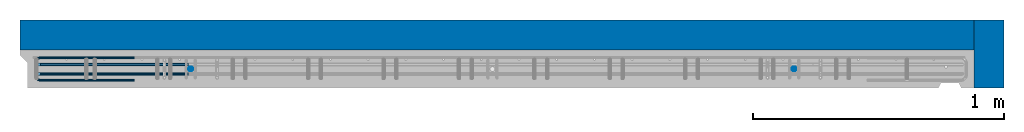
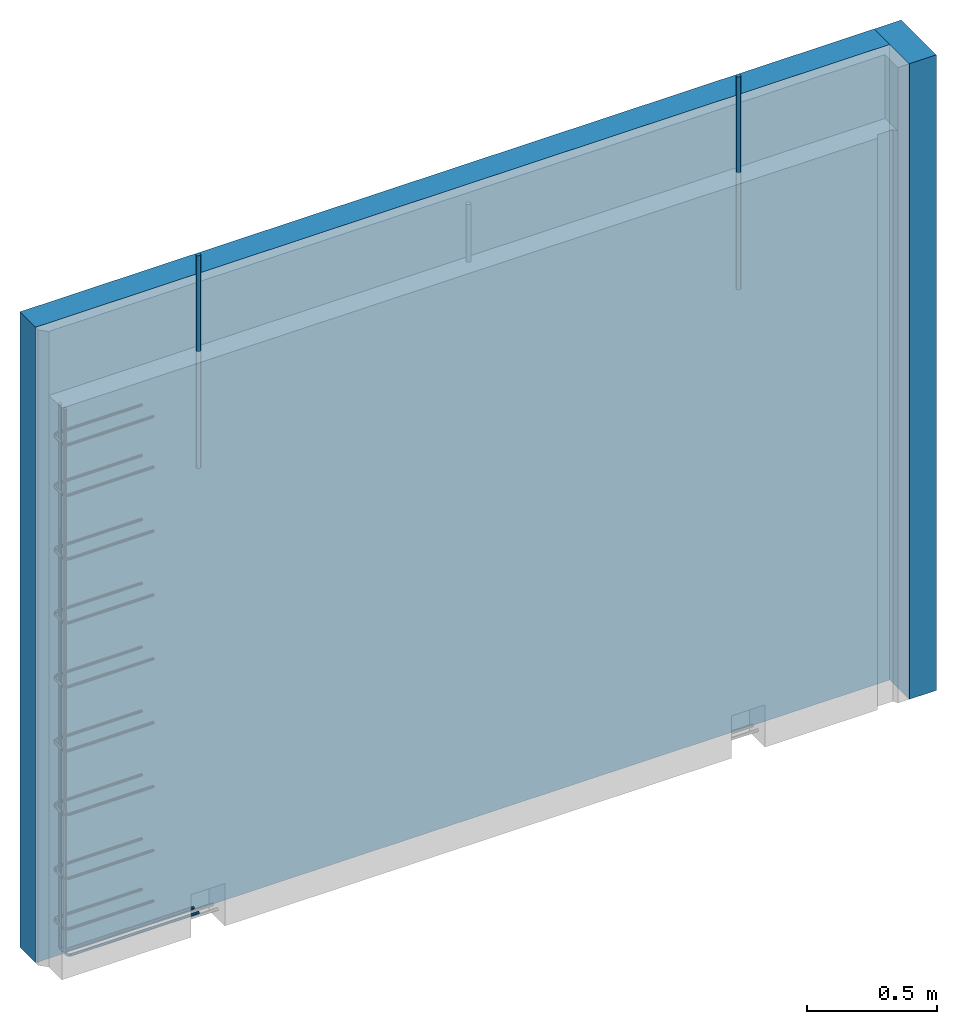
# One storey, part 1 of 9: 3 reinforcing bars, 2 walls, 1 element without a shape of its own.
"""IFC2X3 building model written with IfcOpenShell, lengths in millimetres."""

from ifc_helpers import new_model, entity, si_unit, frame, origin_with_axes, place, context, subcontext, project, spatial, faceted_brep, source, transform, mapped, material, type_object, element, aggregate, save


model = new_model("IFC2X3")

# Units and contexts
model_context = context("Model", 3, precision=1e-05, world=origin_with_axes())
body_context = subcontext(model_context, "Body", "Model", "MODEL_VIEW")
ifc_project = project(units=[si_unit("LENGTHUNIT", "METRE", prefix="MILLI"), si_unit("AREAUNIT", "SQUARE_METRE"), si_unit("VOLUMEUNIT", "CUBIC_METRE"), si_unit("MASSUNIT", "GRAM", prefix="KILO"), si_unit("TIMEUNIT", "SECOND"), si_unit("PLANEANGLEUNIT", "RADIAN"), si_unit("SOLIDANGLEUNIT", "STERADIAN"), si_unit("THERMODYNAMICTEMPERATUREUNIT", "DEGREE_CELSIUS"), si_unit("LUMINOUSINTENSITYUNIT", "LUMEN")], contexts=[model_context])

# Site, building, storey
site_placement = place(None, origin_with_axes())
site = spatial("IfcSite", under=ifc_project, at=site_placement, CompositionType="ELEMENT")
building_placement = place(site_placement, origin_with_axes())
building = spatial("IfcBuilding", under=site, at=building_placement, Name="1", CompositionType="ELEMENT")
storey_placement = place(building_placement, origin_with_axes())
storey = spatial("IfcBuildingStorey", under=building, at=storey_placement, Name="1. kerros", CompositionType="ELEMENT", Elevation=0.0)

# Assembly, walls, reinforcing bars
assembly_placement = place(storey_placement, origin_with_axes())
assembly = element("IfcElementAssembly", 1, at=assembly_placement, inside=storey, AssemblyPlace="NOTDEFINED", PredefinedType="REINFORCEMENT_UNIT")
ifc_material_1 = material(Name="K15")
wall_type = type_object("IfcWallType", Name="2985X120", PredefinedType="NOTDEFINED")
wall_1_placement = place(assembly_placement, frame((41470.0064188799, 6710.00033181262, 1492.49992145828), z_axis=(0.0, 0.0, 1.0), x_axis=(0.999999999502078, -3.15569999841783e-05, 0.0)))
wall_1 = element("IfcWall", 2, at=wall_1_placement, type_object=wall_type, material=ifc_material_1, Name="KINGSPAN", ObjectType="2985X120", context=body_context, shape_type="Brep", body=[
    faceted_brep([(-7.27595761418343e-12, 60.0, -1492.5), (-7.27595761418343e-12, 60.0, 1492.5), (3794.40130344179, 60.0, 1492.5), (3794.40130344179, 60.0, -1492.5), (-7.27595761418343e-12, -60.0000000000009, 1492.5), (3794.40130344179, -60.0, 1492.5), (-7.27595761418343e-12, -60.0000000000009, -1492.5), (3794.40130344179, -60.0, -1492.5)], [[[0, 1, 2, 3]], [[1, 4, 5, 2]], [[4, 6, 7, 5]], [[6, 0, 3, 7]], [[5, 7, 3, 2]], [[6, 4, 1, 0]]]),
])
wall_2_placement = place(assembly_placement, frame((45324.4033074056, 6499.89551753884, 1492.49992151563), z_axis=(0.0, 0.0, 1.0), x_axis=(0.0, 1.0, 0.0)))
wall_2 = element("IfcWall", 3, at=wall_2_placement, type_object=wall_type, material=ifc_material_1, Name="KINGSPAN", ObjectType="2985X120", context=body_context, shape_type="Brep", body=[
    faceted_brep([(-7.27595761418343e-12, 60.0, -1492.5), (-7.27595761418343e-12, 60.0, 1492.5), (269.985074299451, 60.0, 1492.5), (269.985074299451, 60.0, -1492.5), (-7.27595761418343e-12, -60.0000000000009, 1492.5), (269.985074299451, -60.0, 1492.5), (-7.27595761418343e-12, -60.0000000000009, -1492.5), (269.985074299451, -60.0, -1492.5)], [[[0, 1, 2, 3]], [[1, 4, 5, 2]], [[4, 6, 7, 5]], [[6, 0, 3, 7]], [[5, 7, 3, 2]], [[6, 4, 1, 0]]]),
])
ifc_material_2 = material(Name="B500B")
shared_shape_1 = source(origin_with_axes(), body_context, "Body", "AdvancedSweptSolid", [
    entity("IfcSweptDiskSolid", entity("IfcTrimmedCurve", entity("IfcLine", entity("IfcCartesianPoint", [0.0, 0.0, 0.0]), entity("IfcVector", entity("IfcDirection", [1.0, 0.0, 0.0]), 1.0)), [entity("IfcParameterValue", 0.0)], [entity("IfcParameterValue", 1000.0)], True, "PARAMETER"), 9.5, None, 0.0, 1000.0),
])
shared_shape_2 = source(origin_with_axes(), body_context, "Body", "AdvancedSweptSolid", [
    entity("IfcSweptDiskSolid", entity("IfcTrimmedCurve", entity("IfcLine", entity("IfcCartesianPoint", [0.0, 0.0, 0.0]), entity("IfcVector", entity("IfcDirection", [1.0, 0.0, 0.0]), 1.0)), [entity("IfcParameterValue", 0.0)], [entity("IfcParameterValue", 1000.0)], True, "PARAMETER"), 9.5, None, 0.0, 1000.0),
])
reinforcing_bar_1_placement = place(assembly_placement, frame((41470.0027153252, 6590.00033186975, 2539.99992157502), z_axis=(-0.000154210000015155, -0.999999988109638, 0.0), x_axis=(-1.34689347184514e-12, 3.00310696000483e-13, -1.0)))
reinforcing_bar_1 = element("IfcReinforcingBar", 4, at=reinforcing_bar_1_placement, material=ifc_material_2, BarRole="NOTDEFINED", CrossSectionArea=0.0, NominalDiameter=19.0, context=body_context, shape_type="MappedRepresentation", body=[
    mapped(shared_shape_1, transform((-595.0, 679.501855406641, 14.915869183149))),
    mapped(shared_shape_2, transform((-595.0, 3079.50183701462, 14.6187188032445))),
])
ifc_direction_1 = entity("IfcDirection", [0.0, -1.0, 0.0])
shared_shape_3 = source(origin_with_axes(), body_context, "Body", "AdvancedSweptSolid", [
    entity("IfcSweptDiskSolid", entity("IfcCompositeCurve", [entity("IfcCompositeCurveSegment", "CONTINUOUS", True, entity("IfcTrimmedCurve", entity("IfcLine", entity("IfcCartesianPoint", [0.0, 0.0, 0.0]), entity("IfcVector", entity("IfcDirection", [-0.999999999996908, 0.0, 2.4868612773608e-06]), 1.0)), [entity("IfcParameterValue", 0.0)], [entity("IfcParameterValue", 371.999930366745)], True, "PARAMETER")), entity("IfcCompositeCurveSegment", "CONTINUOUS", True, entity("IfcTrimmedCurve", entity("IfcCircle", entity("IfcAxis2Placement3D", entity("IfcCartesianPoint", [-371.999987563404, 0.0, -22.9990748877069]), ifc_direction_1, entity("IfcDirection", [2.48686127751752e-06, 0.0, 0.999999999996908])), 23.0), [entity("IfcParameterValue", 0.0)], [entity("IfcParameterValue", 1.57079881365545)], True, "PARAMETER")), entity("IfcCompositeCurveSegment", "CONTINUOUS", True, entity("IfcTrimmedCurve", entity("IfcLine", entity("IfcCartesianPoint", [-394.999987563404, 0.0, -22.9990748876901]), entity("IfcVector", entity("IfcDirection", [-1.34689347184514e-12, 3.00310696000483e-13, -1.0]), 1.0)), [entity("IfcParameterValue", 0.0)], [entity("IfcParameterValue", 44.0000413663064)], True, "PARAMETER")), entity("IfcCompositeCurveSegment", "CONTINUOUS", True, entity("IfcTrimmedCurve", entity("IfcCircle", entity("IfcAxis2Placement3D", entity("IfcCartesianPoint", [-371.999987563436, 0.0, -66.9991162540133]), ifc_direction_1, entity("IfcDirection", [-1.0, 0.0, 0.0])), 23.0), [entity("IfcParameterValue", 0.0)], [entity("IfcParameterValue", 1.57079383993429)], True, "PARAMETER")), entity("IfcCompositeCurveSegment", "DISCONTINUOUS", True, entity("IfcTrimmedCurve", entity("IfcLine", entity("IfcCartesianPoint", [-372.000044761247, 0.0, -89.9991162539422]), entity("IfcVector", entity("IfcDirection", [0.999999999996908, 0.0, -2.48686133034195e-06]), 1.0)), [entity("IfcParameterValue", 0.0)], [entity("IfcParameterValue", 372.000069630907)], True, "PARAMETER"))], False), 5.0, None, 0.0, 791.141634017549),
])
ifc_direction_2 = entity("IfcDirection", [0.0, -1.0, 0.0])
shared_shape_4 = source(origin_with_axes(), body_context, "Body", "AdvancedSweptSolid", [
    entity("IfcSweptDiskSolid", entity("IfcCompositeCurve", [entity("IfcCompositeCurveSegment", "CONTINUOUS", True, entity("IfcTrimmedCurve", entity("IfcLine", entity("IfcCartesianPoint", [0.0, 0.0, 0.0]), entity("IfcVector", entity("IfcDirection", [-0.999999999996908, 0.0, 2.4868612773608e-06]), 1.0)), [entity("IfcParameterValue", 0.0)], [entity("IfcParameterValue", 371.999930366745)], True, "PARAMETER")), entity("IfcCompositeCurveSegment", "CONTINUOUS", True, entity("IfcTrimmedCurve", entity("IfcCircle", entity("IfcAxis2Placement3D", entity("IfcCartesianPoint", [-371.999987563404, 0.0, -22.9990748877069]), ifc_direction_2, entity("IfcDirection", [2.48686127751752e-06, 0.0, 0.999999999996908])), 23.0), [entity("IfcParameterValue", 0.0)], [entity("IfcParameterValue", 1.57079881365545)], True, "PARAMETER")), entity("IfcCompositeCurveSegment", "CONTINUOUS", True, entity("IfcTrimmedCurve", entity("IfcLine", entity("IfcCartesianPoint", [-394.999987563404, 0.0, -22.9990748876901]), entity("IfcVector", entity("IfcDirection", [-1.34689347184514e-12, 3.00310696000483e-13, -1.0]), 1.0)), [entity("IfcParameterValue", 0.0)], [entity("IfcParameterValue", 44.0000413663064)], True, "PARAMETER")), entity("IfcCompositeCurveSegment", "CONTINUOUS", True, entity("IfcTrimmedCurve", entity("IfcCircle", entity("IfcAxis2Placement3D", entity("IfcCartesianPoint", [-371.999987563436, 0.0, -66.9991162540133]), ifc_direction_2, entity("IfcDirection", [-1.0, 0.0, 0.0])), 23.0), [entity("IfcParameterValue", 0.0)], [entity("IfcParameterValue", 1.57079383993429)], True, "PARAMETER")), entity("IfcCompositeCurveSegment", "DISCONTINUOUS", True, entity("IfcTrimmedCurve", entity("IfcLine", entity("IfcCartesianPoint", [-372.000044761247, 0.0, -89.9991162539422]), entity("IfcVector", entity("IfcDirection", [0.999999999996908, 0.0, -2.48686133034195e-06]), 1.0)), [entity("IfcParameterValue", 0.0)], [entity("IfcParameterValue", 372.000069630907)], True, "PARAMETER"))], False), 5.0, None, 0.0, 791.141634017549),
])
ifc_direction_3 = entity("IfcDirection", [0.0, -1.0, 0.0])
shared_shape_5 = source(origin_with_axes(), body_context, "Body", "AdvancedSweptSolid", [
    entity("IfcSweptDiskSolid", entity("IfcCompositeCurve", [entity("IfcCompositeCurveSegment", "CONTINUOUS", True, entity("IfcTrimmedCurve", entity("IfcLine", entity("IfcCartesianPoint", [0.0, 0.0, 0.0]), entity("IfcVector", entity("IfcDirection", [-0.999999999996908, 0.0, 2.4868612773608e-06]), 1.0)), [entity("IfcParameterValue", 0.0)], [entity("IfcParameterValue", 371.999930366745)], True, "PARAMETER")), entity("IfcCompositeCurveSegment", "CONTINUOUS", True, entity("IfcTrimmedCurve", entity("IfcCircle", entity("IfcAxis2Placement3D", entity("IfcCartesianPoint", [-371.999987563404, 0.0, -22.9990748877069]), ifc_direction_3, entity("IfcDirection", [2.48686127751752e-06, 0.0, 0.999999999996908])), 23.0), [entity("IfcParameterValue", 0.0)], [entity("IfcParameterValue", 1.57079881365545)], True, "PARAMETER")), entity("IfcCompositeCurveSegment", "CONTINUOUS", True, entity("IfcTrimmedCurve", entity("IfcLine", entity("IfcCartesianPoint", [-394.999987563404, 0.0, -22.9990748876901]), entity("IfcVector", entity("IfcDirection", [-1.34689347184514e-12, 3.00310696000483e-13, -1.0]), 1.0)), [entity("IfcParameterValue", 0.0)], [entity("IfcParameterValue", 44.0000413663064)], True, "PARAMETER")), entity("IfcCompositeCurveSegment", "CONTINUOUS", True, entity("IfcTrimmedCurve", entity("IfcCircle", entity("IfcAxis2Placement3D", entity("IfcCartesianPoint", [-371.999987563436, 0.0, -66.9991162540133]), ifc_direction_3, entity("IfcDirection", [-1.0, 0.0, 0.0])), 23.0), [entity("IfcParameterValue", 0.0)], [entity("IfcParameterValue", 1.57079383993429)], True, "PARAMETER")), entity("IfcCompositeCurveSegment", "DISCONTINUOUS", True, entity("IfcTrimmedCurve", entity("IfcLine", entity("IfcCartesianPoint", [-372.000044761247, 0.0, -89.9991162539422]), entity("IfcVector", entity("IfcDirection", [0.999999999996908, 0.0, -2.48686133034195e-06]), 1.0)), [entity("IfcParameterValue", 0.0)], [entity("IfcParameterValue", 372.000069630907)], True, "PARAMETER"))], False), 5.0, None, 0.0, 791.141634017549),
])
ifc_direction_4 = entity("IfcDirection", [0.0, -1.0, 0.0])
shared_shape_6 = source(origin_with_axes(), body_context, "Body", "AdvancedSweptSolid", [
    entity("IfcSweptDiskSolid", entity("IfcCompositeCurve", [entity("IfcCompositeCurveSegment", "CONTINUOUS", True, entity("IfcTrimmedCurve", entity("IfcLine", entity("IfcCartesianPoint", [0.0, 0.0, 0.0]), entity("IfcVector", entity("IfcDirection", [-0.999999999996908, 0.0, 2.4868612773608e-06]), 1.0)), [entity("IfcParameterValue", 0.0)], [entity("IfcParameterValue", 371.999930366745)], True, "PARAMETER")), entity("IfcCompositeCurveSegment", "CONTINUOUS", True, entity("IfcTrimmedCurve", entity("IfcCircle", entity("IfcAxis2Placement3D", entity("IfcCartesianPoint", [-371.999987563404, 0.0, -22.9990748877069]), ifc_direction_4, entity("IfcDirection", [2.48686127751752e-06, 0.0, 0.999999999996908])), 23.0), [entity("IfcParameterValue", 0.0)], [entity("IfcParameterValue", 1.57079881365545)], True, "PARAMETER")), entity("IfcCompositeCurveSegment", "CONTINUOUS", True, entity("IfcTrimmedCurve", entity("IfcLine", entity("IfcCartesianPoint", [-394.999987563404, 0.0, -22.9990748876901]), entity("IfcVector", entity("IfcDirection", [-1.34689347184514e-12, 3.00310696000483e-13, -1.0]), 1.0)), [entity("IfcParameterValue", 0.0)], [entity("IfcParameterValue", 44.0000413663064)], True, "PARAMETER")), entity("IfcCompositeCurveSegment", "CONTINUOUS", True, entity("IfcTrimmedCurve", entity("IfcCircle", entity("IfcAxis2Placement3D", entity("IfcCartesianPoint", [-371.999987563436, 0.0, -66.9991162540133]), ifc_direction_4, entity("IfcDirection", [-1.0, 0.0, 0.0])), 23.0), [entity("IfcParameterValue", 0.0)], [entity("IfcParameterValue", 1.57079383993429)], True, "PARAMETER")), entity("IfcCompositeCurveSegment", "DISCONTINUOUS", True, entity("IfcTrimmedCurve", entity("IfcLine", entity("IfcCartesianPoint", [-372.000044761247, 0.0, -89.9991162539422]), entity("IfcVector", entity("IfcDirection", [0.999999999996908, 0.0, -2.48686133034195e-06]), 1.0)), [entity("IfcParameterValue", 0.0)], [entity("IfcParameterValue", 372.000069630907)], True, "PARAMETER"))], False), 5.0, None, 0.0, 791.141634017549),
])
ifc_direction_5 = entity("IfcDirection", [0.0, -1.0, 0.0])
shared_shape_7 = source(origin_with_axes(), body_context, "Body", "AdvancedSweptSolid", [
    entity("IfcSweptDiskSolid", entity("IfcCompositeCurve", [entity("IfcCompositeCurveSegment", "CONTINUOUS", True, entity("IfcTrimmedCurve", entity("IfcLine", entity("IfcCartesianPoint", [0.0, 0.0, 0.0]), entity("IfcVector", entity("IfcDirection", [-0.999999999996908, 0.0, 2.4868612773608e-06]), 1.0)), [entity("IfcParameterValue", 0.0)], [entity("IfcParameterValue", 371.999930366745)], True, "PARAMETER")), entity("IfcCompositeCurveSegment", "CONTINUOUS", True, entity("IfcTrimmedCurve", entity("IfcCircle", entity("IfcAxis2Placement3D", entity("IfcCartesianPoint", [-371.999987563404, 0.0, -22.9990748877069]), ifc_direction_5, entity("IfcDirection", [2.48686127751752e-06, 0.0, 0.999999999996908])), 23.0), [entity("IfcParameterValue", 0.0)], [entity("IfcParameterValue", 1.57079881365545)], True, "PARAMETER")), entity("IfcCompositeCurveSegment", "CONTINUOUS", True, entity("IfcTrimmedCurve", entity("IfcLine", entity("IfcCartesianPoint", [-394.999987563404, 0.0, -22.9990748876901]), entity("IfcVector", entity("IfcDirection", [-1.34689347184514e-12, 3.00310696000483e-13, -1.0]), 1.0)), [entity("IfcParameterValue", 0.0)], [entity("IfcParameterValue", 44.0000413663064)], True, "PARAMETER")), entity("IfcCompositeCurveSegment", "CONTINUOUS", True, entity("IfcTrimmedCurve", entity("IfcCircle", entity("IfcAxis2Placement3D", entity("IfcCartesianPoint", [-371.999987563436, 0.0, -66.9991162540133]), ifc_direction_5, entity("IfcDirection", [-1.0, 0.0, 0.0])), 23.0), [entity("IfcParameterValue", 0.0)], [entity("IfcParameterValue", 1.57079383993429)], True, "PARAMETER")), entity("IfcCompositeCurveSegment", "DISCONTINUOUS", True, entity("IfcTrimmedCurve", entity("IfcLine", entity("IfcCartesianPoint", [-372.000044761247, 0.0, -89.9991162539422]), entity("IfcVector", entity("IfcDirection", [0.999999999996908, 0.0, -2.48686133034195e-06]), 1.0)), [entity("IfcParameterValue", 0.0)], [entity("IfcParameterValue", 372.000069630907)], True, "PARAMETER"))], False), 5.0, None, 0.0, 791.141634017549),
])
ifc_direction_6 = entity("IfcDirection", [0.0, -1.0, 0.0])
shared_shape_8 = source(origin_with_axes(), body_context, "Body", "AdvancedSweptSolid", [
    entity("IfcSweptDiskSolid", entity("IfcCompositeCurve", [entity("IfcCompositeCurveSegment", "CONTINUOUS", True, entity("IfcTrimmedCurve", entity("IfcLine", entity("IfcCartesianPoint", [0.0, 0.0, 0.0]), entity("IfcVector", entity("IfcDirection", [-0.999999999996908, 0.0, 2.4868612773608e-06]), 1.0)), [entity("IfcParameterValue", 0.0)], [entity("IfcParameterValue", 371.999930366745)], True, "PARAMETER")), entity("IfcCompositeCurveSegment", "CONTINUOUS", True, entity("IfcTrimmedCurve", entity("IfcCircle", entity("IfcAxis2Placement3D", entity("IfcCartesianPoint", [-371.999987563404, 0.0, -22.9990748877069]), ifc_direction_6, entity("IfcDirection", [2.48686127751752e-06, 0.0, 0.999999999996908])), 23.0), [entity("IfcParameterValue", 0.0)], [entity("IfcParameterValue", 1.57079881365545)], True, "PARAMETER")), entity("IfcCompositeCurveSegment", "CONTINUOUS", True, entity("IfcTrimmedCurve", entity("IfcLine", entity("IfcCartesianPoint", [-394.999987563404, 0.0, -22.9990748876901]), entity("IfcVector", entity("IfcDirection", [-1.34689347184514e-12, 3.00310696000483e-13, -1.0]), 1.0)), [entity("IfcParameterValue", 0.0)], [entity("IfcParameterValue", 44.0000413663064)], True, "PARAMETER")), entity("IfcCompositeCurveSegment", "CONTINUOUS", True, entity("IfcTrimmedCurve", entity("IfcCircle", entity("IfcAxis2Placement3D", entity("IfcCartesianPoint", [-371.999987563436, 0.0, -66.9991162540133]), ifc_direction_6, entity("IfcDirection", [-1.0, 0.0, 0.0])), 23.0), [entity("IfcParameterValue", 0.0)], [entity("IfcParameterValue", 1.57079383993429)], True, "PARAMETER")), entity("IfcCompositeCurveSegment", "DISCONTINUOUS", True, entity("IfcTrimmedCurve", entity("IfcLine", entity("IfcCartesianPoint", [-372.000044761247, 0.0, -89.9991162539422]), entity("IfcVector", entity("IfcDirection", [0.999999999996908, 0.0, -2.48686133034195e-06]), 1.0)), [entity("IfcParameterValue", 0.0)], [entity("IfcParameterValue", 372.000069630907)], True, "PARAMETER"))], False), 5.0, None, 0.0, 791.141634017549),
])
ifc_direction_7 = entity("IfcDirection", [0.0, -1.0, 0.0])
shared_shape_9 = source(origin_with_axes(), body_context, "Body", "AdvancedSweptSolid", [
    entity("IfcSweptDiskSolid", entity("IfcCompositeCurve", [entity("IfcCompositeCurveSegment", "CONTINUOUS", True, entity("IfcTrimmedCurve", entity("IfcLine", entity("IfcCartesianPoint", [0.0, 0.0, 0.0]), entity("IfcVector", entity("IfcDirection", [-0.999999999996908, 0.0, 2.4868612773608e-06]), 1.0)), [entity("IfcParameterValue", 0.0)], [entity("IfcParameterValue", 371.999930366745)], True, "PARAMETER")), entity("IfcCompositeCurveSegment", "CONTINUOUS", True, entity("IfcTrimmedCurve", entity("IfcCircle", entity("IfcAxis2Placement3D", entity("IfcCartesianPoint", [-371.999987563404, 0.0, -22.9990748877069]), ifc_direction_7, entity("IfcDirection", [2.48686127751752e-06, 0.0, 0.999999999996908])), 23.0), [entity("IfcParameterValue", 0.0)], [entity("IfcParameterValue", 1.57079881365545)], True, "PARAMETER")), entity("IfcCompositeCurveSegment", "CONTINUOUS", True, entity("IfcTrimmedCurve", entity("IfcLine", entity("IfcCartesianPoint", [-394.999987563404, 0.0, -22.9990748876901]), entity("IfcVector", entity("IfcDirection", [-1.34689347184514e-12, 3.00310696000483e-13, -1.0]), 1.0)), [entity("IfcParameterValue", 0.0)], [entity("IfcParameterValue", 44.0000413663064)], True, "PARAMETER")), entity("IfcCompositeCurveSegment", "CONTINUOUS", True, entity("IfcTrimmedCurve", entity("IfcCircle", entity("IfcAxis2Placement3D", entity("IfcCartesianPoint", [-371.999987563436, 0.0, -66.9991162540133]), ifc_direction_7, entity("IfcDirection", [-1.0, 0.0, 0.0])), 23.0), [entity("IfcParameterValue", 0.0)], [entity("IfcParameterValue", 1.57079383993429)], True, "PARAMETER")), entity("IfcCompositeCurveSegment", "DISCONTINUOUS", True, entity("IfcTrimmedCurve", entity("IfcLine", entity("IfcCartesianPoint", [-372.000044761247, 0.0, -89.9991162539422]), entity("IfcVector", entity("IfcDirection", [0.999999999996908, 0.0, -2.48686133034195e-06]), 1.0)), [entity("IfcParameterValue", 0.0)], [entity("IfcParameterValue", 372.000069630907)], True, "PARAMETER"))], False), 5.0, None, 0.0, 791.141634017549),
])
ifc_direction_8 = entity("IfcDirection", [0.0, -1.0, 0.0])
shared_shape_10 = source(origin_with_axes(), body_context, "Body", "AdvancedSweptSolid", [
    entity("IfcSweptDiskSolid", entity("IfcCompositeCurve", [entity("IfcCompositeCurveSegment", "CONTINUOUS", True, entity("IfcTrimmedCurve", entity("IfcLine", entity("IfcCartesianPoint", [0.0, 0.0, 0.0]), entity("IfcVector", entity("IfcDirection", [-0.999999999996908, 0.0, 2.4868612773608e-06]), 1.0)), [entity("IfcParameterValue", 0.0)], [entity("IfcParameterValue", 371.999930366745)], True, "PARAMETER")), entity("IfcCompositeCurveSegment", "CONTINUOUS", True, entity("IfcTrimmedCurve", entity("IfcCircle", entity("IfcAxis2Placement3D", entity("IfcCartesianPoint", [-371.999987563404, 0.0, -22.9990748877069]), ifc_direction_8, entity("IfcDirection", [2.48686127751752e-06, 0.0, 0.999999999996908])), 23.0), [entity("IfcParameterValue", 0.0)], [entity("IfcParameterValue", 1.57079881365545)], True, "PARAMETER")), entity("IfcCompositeCurveSegment", "CONTINUOUS", True, entity("IfcTrimmedCurve", entity("IfcLine", entity("IfcCartesianPoint", [-394.999987563404, 0.0, -22.9990748876901]), entity("IfcVector", entity("IfcDirection", [-1.34689347184514e-12, 3.00310696000483e-13, -1.0]), 1.0)), [entity("IfcParameterValue", 0.0)], [entity("IfcParameterValue", 44.0000413663064)], True, "PARAMETER")), entity("IfcCompositeCurveSegment", "CONTINUOUS", True, entity("IfcTrimmedCurve", entity("IfcCircle", entity("IfcAxis2Placement3D", entity("IfcCartesianPoint", [-371.999987563436, 0.0, -66.9991162540133]), ifc_direction_8, entity("IfcDirection", [-1.0, 0.0, 0.0])), 23.0), [entity("IfcParameterValue", 0.0)], [entity("IfcParameterValue", 1.57079383993429)], True, "PARAMETER")), entity("IfcCompositeCurveSegment", "DISCONTINUOUS", True, entity("IfcTrimmedCurve", entity("IfcLine", entity("IfcCartesianPoint", [-372.000044761247, 0.0, -89.9991162539422]), entity("IfcVector", entity("IfcDirection", [0.999999999996908, 0.0, -2.48686133034195e-06]), 1.0)), [entity("IfcParameterValue", 0.0)], [entity("IfcParameterValue", 372.000069630907)], True, "PARAMETER"))], False), 5.0, None, 0.0, 791.141634017549),
])
ifc_direction_9 = entity("IfcDirection", [0.0, -1.0, 0.0])
shared_shape_11 = source(origin_with_axes(), body_context, "Body", "AdvancedSweptSolid", [
    entity("IfcSweptDiskSolid", entity("IfcCompositeCurve", [entity("IfcCompositeCurveSegment", "CONTINUOUS", True, entity("IfcTrimmedCurve", entity("IfcLine", entity("IfcCartesianPoint", [0.0, 0.0, 0.0]), entity("IfcVector", entity("IfcDirection", [-0.999999999996908, 0.0, 2.4868612773608e-06]), 1.0)), [entity("IfcParameterValue", 0.0)], [entity("IfcParameterValue", 371.999930366745)], True, "PARAMETER")), entity("IfcCompositeCurveSegment", "CONTINUOUS", True, entity("IfcTrimmedCurve", entity("IfcCircle", entity("IfcAxis2Placement3D", entity("IfcCartesianPoint", [-371.999987563404, 0.0, -22.9990748877069]), ifc_direction_9, entity("IfcDirection", [2.48686127751752e-06, 0.0, 0.999999999996908])), 23.0), [entity("IfcParameterValue", 0.0)], [entity("IfcParameterValue", 1.57079881365545)], True, "PARAMETER")), entity("IfcCompositeCurveSegment", "CONTINUOUS", True, entity("IfcTrimmedCurve", entity("IfcLine", entity("IfcCartesianPoint", [-394.999987563404, 0.0, -22.9990748876901]), entity("IfcVector", entity("IfcDirection", [-1.34689347184514e-12, 3.00310696000483e-13, -1.0]), 1.0)), [entity("IfcParameterValue", 0.0)], [entity("IfcParameterValue", 44.0000413663064)], True, "PARAMETER")), entity("IfcCompositeCurveSegment", "CONTINUOUS", True, entity("IfcTrimmedCurve", entity("IfcCircle", entity("IfcAxis2Placement3D", entity("IfcCartesianPoint", [-371.999987563436, 0.0, -66.9991162540133]), ifc_direction_9, entity("IfcDirection", [-1.0, 0.0, 0.0])), 23.0), [entity("IfcParameterValue", 0.0)], [entity("IfcParameterValue", 1.57079383993429)], True, "PARAMETER")), entity("IfcCompositeCurveSegment", "DISCONTINUOUS", True, entity("IfcTrimmedCurve", entity("IfcLine", entity("IfcCartesianPoint", [-372.000044761247, 0.0, -89.9991162539422]), entity("IfcVector", entity("IfcDirection", [0.999999999996908, 0.0, -2.48686133034195e-06]), 1.0)), [entity("IfcParameterValue", 0.0)], [entity("IfcParameterValue", 372.000069630907)], True, "PARAMETER"))], False), 5.0, None, 0.0, 791.141634017549),
])
reinforcing_bar_2_placement = place(assembly_placement, frame((41530.0045213487, 6649.99858320288, 3794.99988447123), z_axis=(-3.01690000051167e-05, -0.999999999544916, 0.0), x_axis=(0.999999999544916, -3.01690000137153e-05, 0.0)))
reinforcing_bar_2 = element("IfcReinforcingBar", 5, at=reinforcing_bar_2_placement, material=ifc_material_2, BarRole="NOTDEFINED", CrossSectionArea=0.0, NominalDiameter=10.0, context=body_context, shape_type="MappedRepresentation", body=[
    mapped(shared_shape_3, transform((394.998090985915, -1315.0, 120.000302491835))),
    mapped(shared_shape_4, transform((394.998090985915, -1552.5, 120.000302491835))),
    mapped(shared_shape_5, transform((394.998090985915, -1852.5, 120.000302491835))),
    mapped(shared_shape_6, transform((394.998090985915, -2152.5, 120.000302491835))),
    mapped(shared_shape_7, transform((394.998090985915, -2452.5, 120.000302491835))),
    mapped(shared_shape_8, transform((394.998090985915, -2752.5, 120.000302491835))),
    mapped(shared_shape_9, transform((394.998090985915, -3052.5, 120.000302491835))),
    mapped(shared_shape_10, transform((394.998090985915, -3352.5, 120.000302491835))),
    mapped(shared_shape_11, transform((394.998090985915, -3590.0, 120.000302491835))),
])
shared_shape_12 = source(origin_with_axes(), body_context, "Body", "AdvancedSweptSolid", [
    entity("IfcSweptDiskSolid", entity("IfcCompositeCurve", [entity("IfcCompositeCurveSegment", "CONTINUOUS", True, entity("IfcTrimmedCurve", entity("IfcLine", entity("IfcCartesianPoint", [0.0, 0.0, 0.0]), entity("IfcVector", entity("IfcDirection", [0.000121419558664564, 0.0, -0.999999992628645]), 1.0)), [entity("IfcParameterValue", 0.0)], [entity("IfcParameterValue", 2547.11283561247)], True, "PARAMETER")), entity("IfcCompositeCurveSegment", "CONTINUOUS", True, entity("IfcTrimmedCurve", entity("IfcCircle", entity("IfcAxis2Placement3D", entity("IfcCartesianPoint", [29.3092691025996, 0.0, -2547.1092956696]), entity("IfcDirection", [0.0, -1.0, 0.0]), entity("IfcDirection", [-0.999999992628645, 0.0, -0.000121419558664626])), 29.0), [entity("IfcParameterValue", 0.0)], [entity("IfcParameterValue", 1.57067490723436)], True, "PARAMETER")), entity("IfcCompositeCurveSegment", "DISCONTINUOUS", True, entity("IfcTrimmedCurve", entity("IfcLine", entity("IfcCartesianPoint", [29.3092691025541, 0.0, -2576.1092956696]), entity("IfcVector", entity("IfcDirection", [1.0, 0.0, 0.0]), 1.0)), [entity("IfcParameterValue", 0.0)], [entity("IfcParameterValue", 565.004249427335)], True, "PARAMETER"))], False), 6.0, None, 0.0, 3113.68775994704),
])
shared_shape_13 = source(origin_with_axes(), body_context, "Body", "AdvancedSweptSolid", [
    entity("IfcSweptDiskSolid", entity("IfcCompositeCurve", [entity("IfcCompositeCurveSegment", "CONTINUOUS", True, entity("IfcTrimmedCurve", entity("IfcLine", entity("IfcCartesianPoint", [0.0, 0.0, 0.0]), entity("IfcVector", entity("IfcDirection", [0.000121419558664564, 0.0, -0.999999992628645]), 1.0)), [entity("IfcParameterValue", 0.0)], [entity("IfcParameterValue", 2547.11283561247)], True, "PARAMETER")), entity("IfcCompositeCurveSegment", "CONTINUOUS", True, entity("IfcTrimmedCurve", entity("IfcCircle", entity("IfcAxis2Placement3D", entity("IfcCartesianPoint", [29.3092691025996, 0.0, -2547.1092956696]), entity("IfcDirection", [0.0, -1.0, 0.0]), entity("IfcDirection", [-0.999999992628645, 0.0, -0.000121419558664626])), 29.0), [entity("IfcParameterValue", 0.0)], [entity("IfcParameterValue", 1.57067490723436)], True, "PARAMETER")), entity("IfcCompositeCurveSegment", "DISCONTINUOUS", True, entity("IfcTrimmedCurve", entity("IfcLine", entity("IfcCartesianPoint", [29.3092691025541, 0.0, -2576.1092956696]), entity("IfcVector", entity("IfcDirection", [1.0, 0.0, 0.0]), 1.0)), [entity("IfcParameterValue", 0.0)], [entity("IfcParameterValue", 565.004249427335)], True, "PARAMETER"))], False), 6.0, None, 0.0, 3113.68775994704),
])
reinforcing_bar_3_placement = place(assembly_placement, frame((41500.4033, 6499.8868, -0.1038), z_axis=(-2.75499999916065e-05, 0.0, 0.999999999620499), x_axis=(0.999999999620499, 0.0, 2.75499999895447e-05)))
reinforcing_bar_3 = element("IfcReinforcingBar", 6, at=reinforcing_bar_3_placement, material=ifc_material_2, BarRole="NOTDEFINED", CrossSectionArea=0.0, NominalDiameter=12.0, context=body_context, shape_type="MappedRepresentation", body=[
    mapped(shared_shape_12, transform((45.6800465290653, 56.0, 2635.10929566948))),
    mapped(shared_shape_13, transform((45.6800465290653, 93.4930772160214, 2635.10929566948))),
])
aggregate(assembly, [wall_1, wall_2, reinforcing_bar_1, reinforcing_bar_2, reinforcing_bar_3])

save(model, "model.ifc")
